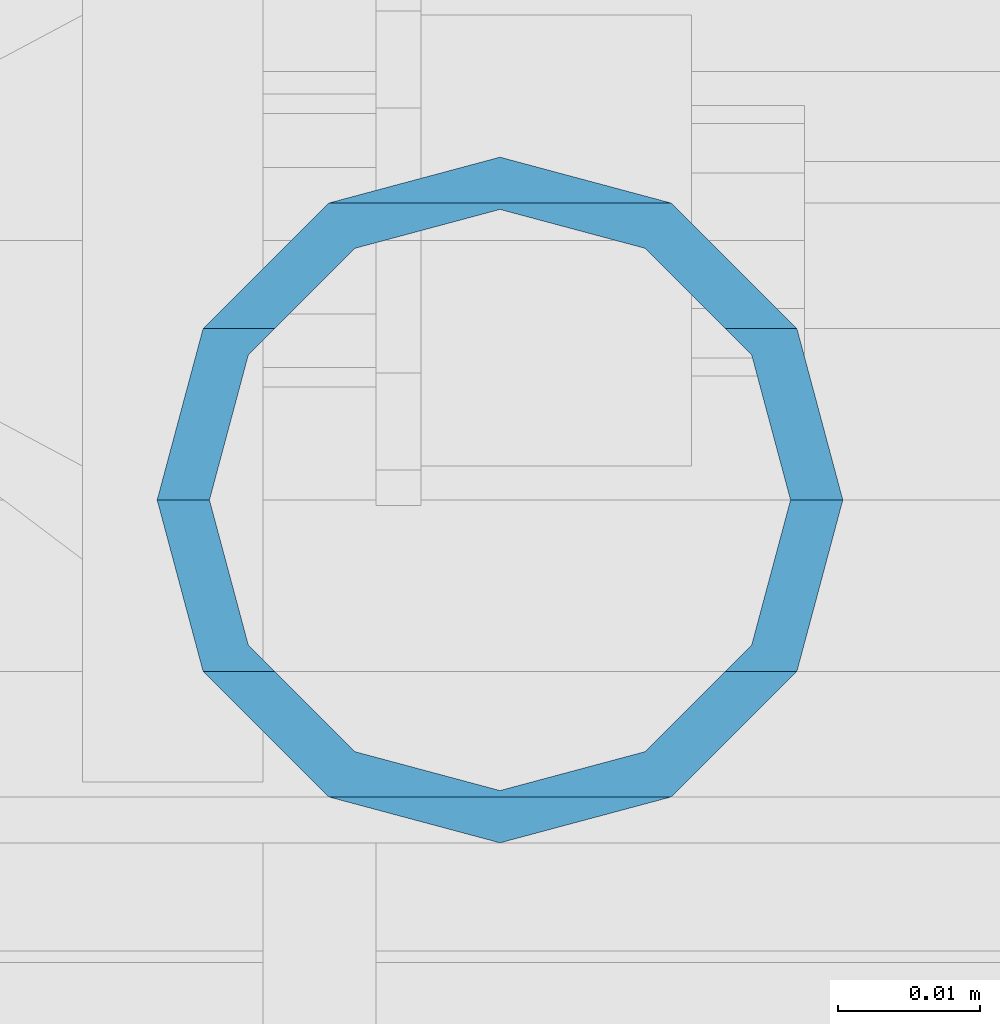
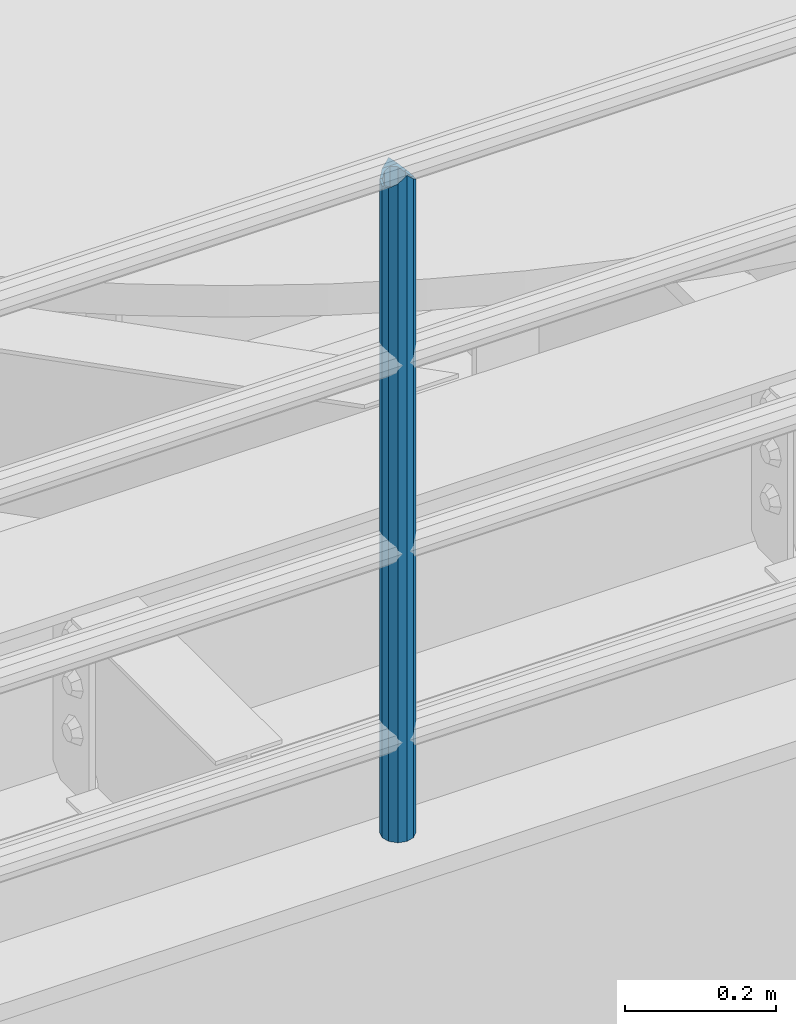
# One storey, part 615 of 1876: 1 column, 1 element without a shape of its own.
"""IFC2X3 building model written with IfcOpenShell, lengths in millimetres."""

from ifc_helpers import new_model, si_unit, frame, origin_with_axes, place, context, subcontext, project, spatial, faceted_brep, material, type_object, element, aggregate, save


model = new_model("IFC2X3")

# Units and contexts
model_context = context("Model", 3, precision=1e-05, world=origin_with_axes())
body_context = subcontext(model_context, "Body", "Model", "MODEL_VIEW")
ifc_project = project(units=[si_unit("LENGTHUNIT", "METRE", prefix="MILLI"), si_unit("AREAUNIT", "SQUARE_METRE"), si_unit("VOLUMEUNIT", "CUBIC_METRE"), si_unit("MASSUNIT", "GRAM", prefix="KILO"), si_unit("TIMEUNIT", "SECOND"), si_unit("PLANEANGLEUNIT", "RADIAN"), si_unit("SOLIDANGLEUNIT", "STERADIAN"), si_unit("THERMODYNAMICTEMPERATUREUNIT", "DEGREE_CELSIUS"), si_unit("LUMINOUSINTENSITYUNIT", "LUMEN")], contexts=[model_context])

# Site, building, storey
site_placement = place(None, origin_with_axes())
site = spatial("IfcSite", under=ifc_project, at=site_placement, CompositionType="ELEMENT")
building_placement = place(site_placement, origin_with_axes())
building = spatial("IfcBuilding", under=site, at=building_placement, Name="Undefined", CompositionType="ELEMENT")
storey_placement = place(building_placement, origin_with_axes())
storey = spatial("IfcBuildingStorey", under=building, at=storey_placement, Name="Undefined", CompositionType="ELEMENT", Elevation=0.0)

# Assembly, column
assembly_placement = place(storey_placement, origin_with_axes())
assembly = element("IfcElementAssembly", 1, at=assembly_placement, inside=storey, Name="RAIL", AssemblyPlace="NOTDEFINED", PredefinedType="RIGID_FRAME")
ifc_material = material()
column_type = type_object("IfcColumnType", Name="PIPE1-1/2SCH40", PredefinedType="NOTDEFINED")
column_placement = place(assembly_placement, frame((2870.19999998823, -4654.55000114554, 13309.6), z_axis=(0.0, 1.0, 0.0), x_axis=(0.0, 0.0, 1.0)))
column = element("IfcColumn", 2, at=column_placement, type_object=column_type, material=ifc_material, Name="POST", ObjectType="PIPE1-1/2SCH40", context=body_context, shape_type="Brep", body=[
    faceted_brep([(1076.325, 0.0, -24.1300000000001), (1064.26, 12.065, -20.8971929933186), (1064.26, -12.0650000000001, -20.8971929933186), (1054.93437856882, 17.7076214311801, 10.2235000000001), (1052.195, 20.4470000000001, 0.0), (1052.195, 24.13, 0.0), (1055.42780700668, 20.8971929933185, 12.0649999999996), (1055.42780700668, 15.8661214311869, 12.0649999999932), (1055.42780700668, 15.8661214311742, -12.065000000006), (1055.42780700668, 20.8971929933185, -12.0649999999996), (1054.93437856882, 17.7076214311801, -10.2235000000001), (1061.07042843786, 10.2235000000001, -17.7076214311801), (1063.80980700668, 0.0, -20.4470000000001), (1061.07042843786, -10.2235000000001, -17.7076214311801), (1055.42780700668, -15.8661214311742, -12.065000000006), (1055.42780700668, -20.8971929933184, -12.0649999999996), (1054.93437856882, -17.7076214311801, -10.2235000000001), (1052.195, -20.4470000000001, 0.0), (1052.195, -24.1300000000001, 0.0), (1054.93437856882, -17.7076214311801, 10.2235000000001), (1055.42780700668, -15.8661214311869, 12.0649999999932), (1055.42780700668, -20.8971929933184, 12.0649999999996), (1076.325, 0.0, 24.1300000000001), (1064.26, -12.0650000000001, 20.8971929933186), (1064.26, 12.065, 20.8971929933186), (1061.07042843787, -10.2235000000001, 17.7076214311801), (1063.80980700669, 0.0, 20.4470000000001), (1061.07042843787, 10.2235000000001, 17.7076214311801), (0.0, -20.8971929933184, -12.0649999999996), (0.0, -12.0650000000001, -20.8971929933186), (-1.45519152283669e-11, 0.0, -24.130000000001), (0.0, 12.0650000000001, -20.8971929933186), (0.0, 20.8971929933184, -12.0649999999996), (0.0, 24.1299999999992, 0.0), (0.0, 20.8971929933184, 12.0649999999996), (0.0, 12.0650000000001, 20.8971929933186), (-1.45519152283669e-11, 0.0, 24.130000000001), (0.0, -20.8971929933184, 12.0649999999996), (0.0, -24.1299999999992, 0.0), (0.0, -12.0650000000001, 20.8971929933186), (0.0, -17.7076214311803, -10.2235000000001), (0.0, -10.2235000000001, -17.7076214311801), (-1.45519152283669e-11, 0.0, -20.4470000000001), (0.0, 10.2235000000001, -17.7076214311801), (0.0, 17.7076214311803, -10.2235000000001), (0.0, 20.4469999999999, 0.0), (0.0, 17.7076214311803, 10.2235000000001), (0.0, 10.2235000000001, 17.7076214311801), (-1.45519152283669e-11, 0.0, 20.4470000000001), (0.0, -10.2235000000001, 17.7076214311801), (0.0, -17.7076214311803, 10.2235000000001), (0.0, -20.4469999999999, 0.0)], [[[0, 1, 2]], [[3, 4, 5, 6, 7]], [[8, 9, 5, 4, 10]], [[2, 1, 9, 8, 11, 12, 13, 14, 15]], [[15, 14, 16, 17, 18]], [[18, 17, 19, 20, 21]], [[22, 23, 24]], [[21, 20, 25, 26, 27, 7, 6, 24, 23]], [[28, 29, 2, 15]], [[29, 30, 0, 2]], [[30, 31, 1, 0]], [[31, 32, 9, 1]], [[32, 33, 5, 9]], [[33, 34, 6, 5]], [[34, 35, 24, 6]], [[35, 36, 22, 24]], [[37, 38, 18, 21]], [[39, 37, 21, 23]], [[36, 39, 23, 22]], [[38, 28, 15, 18]], [[37, 39, 36, 35, 34, 33, 32, 31, 30, 29, 28, 38], [40, 41, 42, 43, 44, 45, 46, 47, 48, 49, 50, 51]], [[49, 48, 26, 25]], [[19, 50, 49, 25, 20]], [[51, 50, 19, 17]], [[40, 51, 17, 16]], [[41, 40, 16, 14, 13]], [[42, 41, 13, 12]], [[43, 42, 12, 11]], [[10, 44, 43, 11, 8]], [[45, 44, 10, 4]], [[46, 45, 4, 3]], [[47, 46, 3, 7, 27]], [[48, 47, 27, 26]]]),
])
aggregate(assembly, [column])

save(model, "model.ifc")
